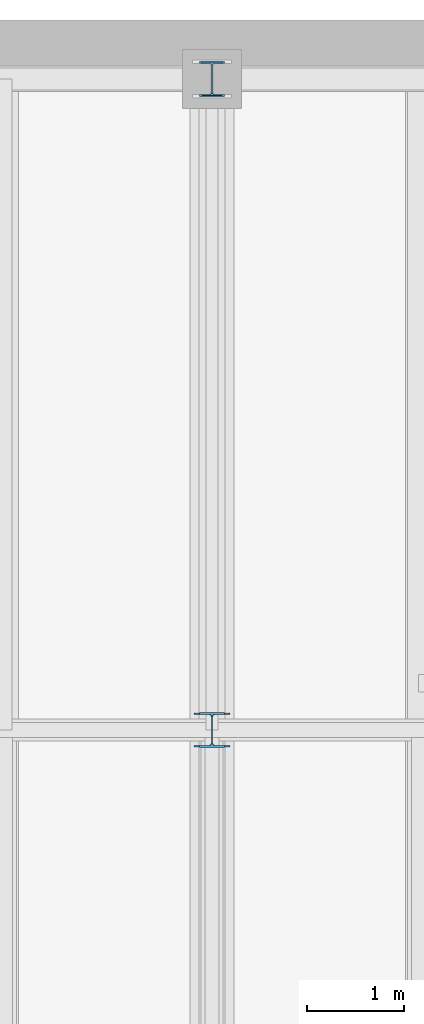
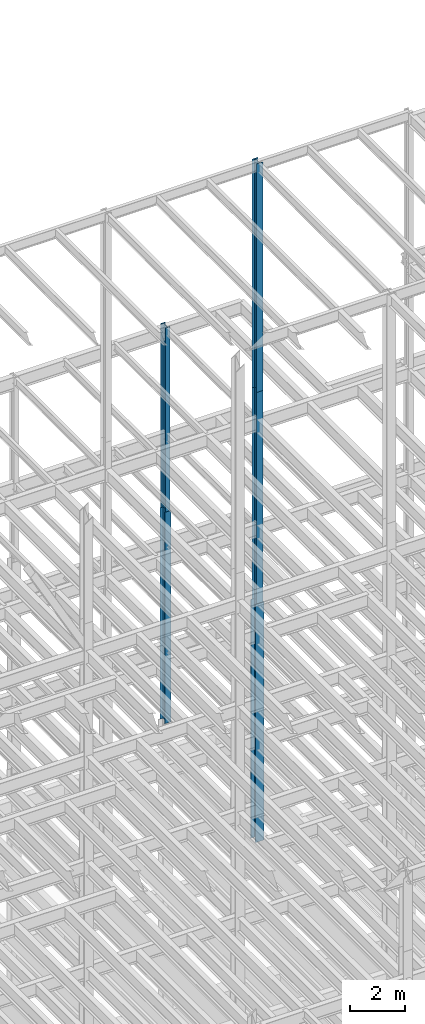
# One storey, part 66 of 150: 5 columns.
"""IFC2X3 building model written with IfcOpenShell, lengths in millimetres."""

from ifc_helpers import new_model, si_unit, frame, origin_with_axes, origin_2d_with_axis, place, context, subcontext, project, spatial, i_section, extrude, material, type_object, element, save


model = new_model("IFC2X3")

# Units and contexts
model_context = context("Model", 3, precision=1e-05, world=origin_with_axes())
body_context = subcontext(model_context, "Body", "Model", "MODEL_VIEW")
ifc_project = project(units=[si_unit("LENGTHUNIT", "METRE", prefix="MILLI"), si_unit("AREAUNIT", "SQUARE_METRE"), si_unit("VOLUMEUNIT", "CUBIC_METRE"), si_unit("MASSUNIT", "GRAM", prefix="KILO"), si_unit("TIMEUNIT", "SECOND"), si_unit("PLANEANGLEUNIT", "RADIAN"), si_unit("SOLIDANGLEUNIT", "STERADIAN"), si_unit("THERMODYNAMICTEMPERATUREUNIT", "DEGREE_CELSIUS"), si_unit("LUMINOUSINTENSITYUNIT", "LUMEN")], contexts=[model_context])

# Site, building, storey
site_placement = place(None, origin_with_axes())
site = spatial("IfcSite", under=ifc_project, at=site_placement, CompositionType="ELEMENT")
building_placement = place(site_placement, origin_with_axes())
building = spatial("IfcBuilding", under=site, at=building_placement, Name="Undefined", CompositionType="ELEMENT")
storey_placement = place(building_placement, origin_with_axes())
storey = spatial("IfcBuildingStorey", under=building, at=storey_placement, Name="Undefined", CompositionType="ELEMENT", Elevation=0.0)

# Columns
ifc_material = material(Name="STEEL/A992")
column_type_1 = type_object("IfcColumnType", Name="W14X43", PredefinedType="NOTDEFINED")
column_1_placement = place(storey_placement, frame((43789.6, 38862.0, 46253.4), z_axis=(0.0, 0.0, 1.0), x_axis=(1.0, 0.0, 0.0)))
element("IfcColumn", 1, at=column_1_placement, inside=storey, type_object=column_type_1, material=ifc_material, Name="COLUMN", ObjectType="W14X43", context=body_context, shape_type="SweptSolid", body=[
    extrude(i_section(OverallWidth=203.2, OverallDepth=346.075, WebThickness=7.9375, FlangeThickness=13.462, FilletRadius=21.4629, at=origin_2d_with_axis()), frame((0.0, 0.0, 8229.60000000002), z_axis=(0.0, 0.0, -1.0), x_axis=(-1.0, 0.0, 0.0)), (0.0, 0.0, 1.0), 8229.60000000002),
])
column_type_2 = type_object("IfcColumnType", Name="W14X90", PredefinedType="NOTDEFINED")
column_2_placement = place(storey_placement, frame((43789.6, 32131.0, 35585.4), z_axis=(0.0, 0.0, 1.0), x_axis=(1.0, 0.0, 0.0)))
element("IfcColumn", 2, at=column_2_placement, inside=storey, type_object=column_type_2, material=ifc_material, Name="COLUMN", ObjectType="W14X90", context=body_context, shape_type="SweptSolid", body=[
    extrude(i_section(OverallWidth=368.3, OverallDepth=355.6, WebThickness=11.1125, FlangeThickness=18.034, FilletRadius=32.7659, at=origin_2d_with_axis()), frame((0.0, 0.0, 10668.0009448801), z_axis=(0.0, 0.0, -1.0), x_axis=(-1.0, 0.0, 0.0)), (0.0, 0.0, 1.0), 10668.0009448801),
])
column_type_3 = type_object("IfcColumnType", Name="W14X74", PredefinedType="NOTDEFINED")
column_3_placement = place(storey_placement, frame((43789.6, 38862.0, 36804.6012877801), z_axis=(0.0, 0.0, 1.0), x_axis=(1.0, 0.0, 0.0)))
element("IfcColumn", 3, at=column_3_placement, inside=storey, type_object=column_type_3, material=ifc_material, Name="COLUMN", ObjectType="W14X74", context=body_context, shape_type="SweptSolid", body=[
    extrude(i_section(OverallWidth=256.54, OverallDepth=358.775, WebThickness=11.1125, FlangeThickness=19.939, FilletRadius=21.336, at=origin_2d_with_axis()), frame((0.0, 0.0, 9448.79871221987), z_axis=(0.0, 0.0, -1.0), x_axis=(-1.0, 0.0, 0.0)), (0.0, 0.0, 1.0), 9448.79871221987),
])
column_4_placement = place(storey_placement, frame((43789.6, 32131.0, 55702.2), z_axis=(0.0, 0.0, 1.0), x_axis=(1.0, 0.0, 0.0)))
element("IfcColumn", 4, at=column_4_placement, inside=storey, type_object=column_type_3, material=ifc_material, Name="COLUMN", ObjectType="W14X74", context=body_context, shape_type="SweptSolid", body=[
    extrude(i_section(OverallWidth=256.54, OverallDepth=358.775, WebThickness=11.1125, FlangeThickness=19.939, FilletRadius=21.336, at=origin_2d_with_axis()), frame((0.0, 0.0, 10210.8), z_axis=(0.0, 0.0, -1.0), x_axis=(-1.0, 0.0, 0.0)), (0.0, 0.0, 1.0), 10210.8),
])
column_5_placement = place(storey_placement, frame((43789.6, 32131.0, 46253.4009448801), z_axis=(0.0, 0.0, 1.0), x_axis=(1.0, 0.0, 0.0)))
element("IfcColumn", 5, at=column_5_placement, inside=storey, type_object=column_type_3, material=ifc_material, Name="COLUMN", ObjectType="W14X74", context=body_context, shape_type="SweptSolid", body=[
    extrude(i_section(OverallWidth=256.54, OverallDepth=358.775, WebThickness=11.1125, FlangeThickness=19.939, FilletRadius=21.336, at=origin_2d_with_axis()), frame((0.0, 0.0, 9448.79811024001), z_axis=(0.0, 0.0, -1.0), x_axis=(-1.0, 0.0, 0.0)), (0.0, 0.0, 1.0), 9448.79811024001),
])

save(model, "model.ifc")
